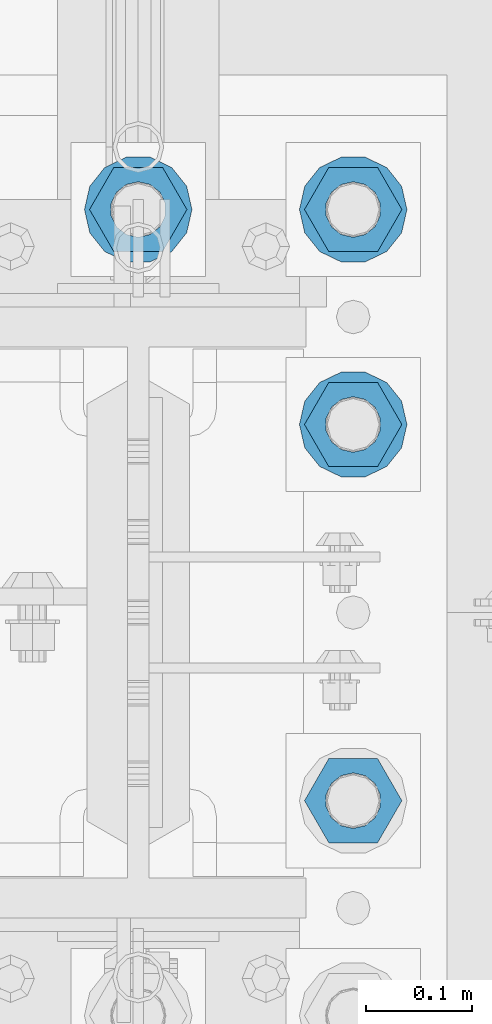
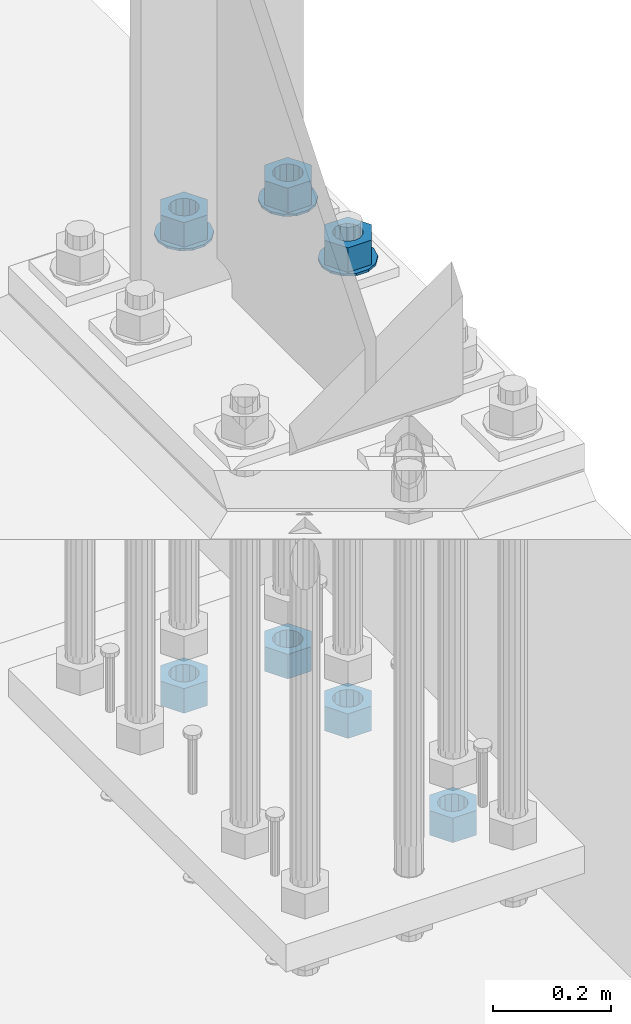
# One storey, part 858 of 1876: 10 columns, 1 element without a shape of its own.
"""IFC2X3 building model written with IfcOpenShell, lengths in millimetres."""

from ifc_helpers import new_model, si_unit, frame, origin_with_axes, place, context, subcontext, project, spatial, faceted_brep, material, type_object, element, aggregate, save


model = new_model("IFC2X3")

# Units and contexts
model_context = context("Model", 3, precision=1e-05, world=origin_with_axes())
body_context = subcontext(model_context, "Body", "Model", "MODEL_VIEW")
ifc_project = project(units=[si_unit("LENGTHUNIT", "METRE", prefix="MILLI"), si_unit("AREAUNIT", "SQUARE_METRE"), si_unit("VOLUMEUNIT", "CUBIC_METRE"), si_unit("MASSUNIT", "GRAM", prefix="KILO"), si_unit("TIMEUNIT", "SECOND"), si_unit("PLANEANGLEUNIT", "RADIAN"), si_unit("SOLIDANGLEUNIT", "STERADIAN"), si_unit("THERMODYNAMICTEMPERATUREUNIT", "DEGREE_CELSIUS"), si_unit("LUMINOUSINTENSITYUNIT", "LUMEN")], contexts=[model_context])

# Site, building, storey
site_placement = place(None, origin_with_axes())
site = spatial("IfcSite", under=ifc_project, at=site_placement, CompositionType="ELEMENT")
building_placement = place(site_placement, origin_with_axes())
building = spatial("IfcBuilding", under=site, at=building_placement, Name="Undefined", CompositionType="ELEMENT")
storey_placement = place(building_placement, origin_with_axes())
storey = spatial("IfcBuildingStorey", under=building, at=storey_placement, Name="Undefined", CompositionType="ELEMENT", Elevation=0.0)

# Assembly, columns
assembly_placement = place(storey_placement, origin_with_axes())
assembly = element("IfcElementAssembly", 1, at=assembly_placement, inside=storey, Name="TEMPLATE", AssemblyPlace="NOTDEFINED", PredefinedType="RIGID_FRAME")
ifc_material_1 = material(Name="STEEL/F436")
column_type_1 = type_object("IfcColumnType", Name="2_WASHER", PredefinedType="NOTDEFINED")
column_1_placement = place(assembly_placement, frame((7823.2, 7797.8, 119.0625), z_axis=(0.0, 1.0, 0.0), x_axis=(0.0, 0.0, -1.0)))
column_1 = element("IfcColumn", 2, at=column_1_placement, type_object=column_type_1, material=ifc_material_1, Name="WASHER", ObjectType="2_WASHER", context=body_context, shape_type="Brep", body=[
    faceted_brep([(0.0, -50.7999992370605, 9.09494701772928e-13), (0.0, -45.7692178020588, -22.0412936161442), (4.7625, -45.7692178020588, -22.0412936161442), (4.7625, -50.7999992370605, 9.09494701772928e-13), (0.0, -31.6732814587394, -39.7170387128856), (4.7625, -31.6732814587394, -39.7170387128856), (0.0, -11.3040632752118, -49.5263371950259), (4.7625, -11.3040632752118, -49.5263371950259), (0.0, 11.30406327521, -49.5263371950264), (4.7625, 11.30406327521, -49.5263371950264), (0.0, 31.6732814587385, -39.7170387128867), (4.7625, 31.6732814587385, -39.7170387128867), (0.0, 45.7692178020579, -22.041293616146), (4.7625, 45.7692178020579, -22.041293616146), (0.0, 50.7999992370605, -9.09494701772928e-13), (4.7625, 50.7999992370605, -9.09494701772928e-13), (0.0, 45.7692178020588, 22.0412936161442), (4.7625, 45.7692178020588, 22.0412936161442), (0.0, 31.6732814587394, 39.7170387128856), (4.7625, 31.6732814587394, 39.7170387128856), (0.0, 11.3040632752118, 49.5263371950259), (4.7625, 11.3040632752118, 49.5263371950259), (0.0, -11.30406327521, 49.5263371950264), (4.7625, -11.30406327521, 49.5263371950264), (0.0, -31.6732814587385, 39.7170387128867), (4.7625, -31.6732814587385, 39.7170387128867), (0.0, -45.7692178020579, 22.041293616146), (4.7625, -45.7692178020579, 22.041293616146), (0.0, 0.0, 26.9869995117188), (0.0, 11.7093983825444, 24.3146012721213), (4.7625, 11.7093983825444, 24.3146012721213), (4.7625, 0.0, 26.9869995117188), (0.0, 21.0996520289491, 16.8262864224157), (4.7625, 21.0996520289491, 16.8262864224157), (0.0, 26.3108629296712, 6.00524193584533), (4.7625, 26.3108629296712, 6.00524193584533), (0.0, 26.3108629296712, -6.00524193584533), (4.7625, 26.3108629296712, -6.00524193584533), (0.0, 21.0996520289491, -16.8262864224157), (4.7625, 21.0996520289491, -16.8262864224157), (0.0, 11.7093983825444, -24.3146012721213), (4.7625, 11.7093983825444, -24.3146012721213), (0.0, 0.0, -26.9869995117188), (4.7625, 0.0, -26.9869995117188), (0.0, -11.7093983825444, -24.3146012721213), (4.7625, -11.7093983825444, -24.3146012721213), (0.0, -21.0996520289491, -16.8262864224157), (4.7625, -21.0996520289491, -16.8262864224157), (0.0, -26.3108629296712, -6.00524193584533), (4.7625, -26.3108629296712, -6.00524193584533), (0.0, -26.3108629296712, 6.00524193584533), (4.7625, -26.3108629296712, 6.00524193584533), (0.0, -21.0996520289491, 16.8262864224157), (4.7625, -21.0996520289491, 16.8262864224157), (0.0, -11.7093983825444, 24.3146012721213), (4.7625, -11.7093983825444, 24.3146012721213)], [[[0, 1, 2, 3]], [[1, 4, 5, 2]], [[4, 6, 7, 5]], [[6, 8, 9, 7]], [[8, 10, 11, 9]], [[10, 12, 13, 11]], [[12, 14, 15, 13]], [[14, 16, 17, 15]], [[16, 18, 19, 17]], [[18, 20, 21, 19]], [[20, 22, 23, 21]], [[22, 24, 25, 23]], [[24, 26, 27, 25]], [[26, 0, 3, 27]], [[28, 29, 30, 31]], [[29, 32, 33, 30]], [[32, 34, 35, 33]], [[34, 36, 37, 35]], [[36, 38, 39, 37]], [[38, 40, 41, 39]], [[40, 42, 43, 41]], [[42, 44, 45, 43]], [[44, 46, 47, 45]], [[46, 48, 49, 47]], [[48, 50, 51, 49]], [[50, 52, 53, 51]], [[52, 54, 55, 53]], [[54, 28, 31, 55]], [[5, 7, 9, 11, 13, 15, 17, 19, 21, 23, 25, 27, 3, 2], [33, 35, 37, 39, 41, 43, 45, 47, 49, 51, 53, 55, 31, 30]], [[26, 24, 22, 20, 18, 16, 14, 12, 10, 8, 6, 4, 1, 0], [54, 52, 50, 48, 46, 44, 42, 40, 38, 36, 34, 32, 29, 28]]]),
])
column_2_placement = place(assembly_placement, frame((7620.0, 8001.0, 119.0625), z_axis=(0.0, -1.0, 0.0), x_axis=(0.0, 0.0, -1.0)))
column_2 = element("IfcColumn", 3, at=column_2_placement, type_object=column_type_1, material=ifc_material_1, Name="WASHER", ObjectType="2_WASHER", context=body_context, shape_type="Brep", body=[
    faceted_brep([(0.0, -50.7999992370605, 9.09494701772928e-13), (0.0, -45.7692178020588, -22.0412936161442), (4.7625, -45.7692178020588, -22.0412936161442), (4.7625, -50.7999992370605, 9.09494701772928e-13), (0.0, -31.6732814587394, -39.7170387128856), (4.7625, -31.6732814587394, -39.7170387128856), (0.0, -11.3040632752118, -49.5263371950259), (4.7625, -11.3040632752118, -49.5263371950259), (0.0, 11.30406327521, -49.5263371950264), (4.7625, 11.30406327521, -49.5263371950264), (0.0, 31.6732814587385, -39.7170387128867), (4.7625, 31.6732814587385, -39.7170387128867), (0.0, 45.7692178020579, -22.041293616146), (4.7625, 45.7692178020579, -22.041293616146), (0.0, 50.7999992370605, -9.09494701772928e-13), (4.7625, 50.7999992370605, -9.09494701772928e-13), (0.0, 45.7692178020588, 22.0412936161442), (4.7625, 45.7692178020588, 22.0412936161442), (0.0, 31.6732814587394, 39.7170387128856), (4.7625, 31.6732814587394, 39.7170387128856), (0.0, 11.3040632752118, 49.5263371950259), (4.7625, 11.3040632752118, 49.5263371950259), (0.0, -11.30406327521, 49.5263371950264), (4.7625, -11.30406327521, 49.5263371950264), (0.0, -31.6732814587385, 39.7170387128867), (4.7625, -31.6732814587385, 39.7170387128867), (0.0, -45.7692178020579, 22.041293616146), (4.7625, -45.7692178020579, 22.041293616146), (0.0, 0.0, 26.9869995117188), (0.0, 11.7093983825444, 24.3146012721213), (4.7625, 11.7093983825444, 24.3146012721213), (4.7625, 0.0, 26.9869995117188), (0.0, 21.0996520289491, 16.8262864224157), (4.7625, 21.0996520289491, 16.8262864224157), (0.0, 26.3108629296712, 6.00524193584533), (4.7625, 26.3108629296712, 6.00524193584533), (0.0, 26.3108629296712, -6.00524193584533), (4.7625, 26.3108629296712, -6.00524193584533), (0.0, 21.0996520289491, -16.8262864224157), (4.7625, 21.0996520289491, -16.8262864224157), (0.0, 11.7093983825444, -24.3146012721213), (4.7625, 11.7093983825444, -24.3146012721213), (0.0, 0.0, -26.9869995117188), (4.7625, 0.0, -26.9869995117188), (0.0, -11.7093983825444, -24.3146012721213), (4.7625, -11.7093983825444, -24.3146012721213), (0.0, -21.0996520289491, -16.8262864224157), (4.7625, -21.0996520289491, -16.8262864224157), (0.0, -26.3108629296712, -6.00524193584533), (4.7625, -26.3108629296712, -6.00524193584533), (0.0, -26.3108629296712, 6.00524193584533), (4.7625, -26.3108629296712, 6.00524193584533), (0.0, -21.0996520289491, 16.8262864224157), (4.7625, -21.0996520289491, 16.8262864224157), (0.0, -11.7093983825444, 24.3146012721213), (4.7625, -11.7093983825444, 24.3146012721213)], [[[0, 1, 2, 3]], [[1, 4, 5, 2]], [[4, 6, 7, 5]], [[6, 8, 9, 7]], [[8, 10, 11, 9]], [[10, 12, 13, 11]], [[12, 14, 15, 13]], [[14, 16, 17, 15]], [[16, 18, 19, 17]], [[18, 20, 21, 19]], [[20, 22, 23, 21]], [[22, 24, 25, 23]], [[24, 26, 27, 25]], [[26, 0, 3, 27]], [[28, 29, 30, 31]], [[29, 32, 33, 30]], [[32, 34, 35, 33]], [[34, 36, 37, 35]], [[36, 38, 39, 37]], [[38, 40, 41, 39]], [[40, 42, 43, 41]], [[42, 44, 45, 43]], [[44, 46, 47, 45]], [[46, 48, 49, 47]], [[48, 50, 51, 49]], [[50, 52, 53, 51]], [[52, 54, 55, 53]], [[54, 28, 31, 55]], [[5, 7, 9, 11, 13, 15, 17, 19, 21, 23, 25, 27, 3, 2], [33, 35, 37, 39, 41, 43, 45, 47, 49, 51, 53, 55, 31, 30]], [[26, 24, 22, 20, 18, 16, 14, 12, 10, 8, 6, 4, 1, 0], [54, 52, 50, 48, 46, 44, 42, 40, 38, 36, 34, 32, 29, 28]]]),
])
column_3_placement = place(assembly_placement, frame((7823.2, 8001.0, 119.0625), z_axis=(0.0, 1.0, 0.0), x_axis=(0.0, 0.0, -1.0)))
column_3 = element("IfcColumn", 4, at=column_3_placement, type_object=column_type_1, material=ifc_material_1, Name="WASHER", ObjectType="2_WASHER", context=body_context, shape_type="Brep", body=[
    faceted_brep([(0.0, -50.7999992370605, 9.09494701772928e-13), (0.0, -45.7692178020588, -22.0412936161442), (4.7625, -45.7692178020588, -22.0412936161442), (4.7625, -50.7999992370605, 9.09494701772928e-13), (0.0, -31.6732814587394, -39.7170387128856), (4.7625, -31.6732814587394, -39.7170387128856), (0.0, -11.3040632752118, -49.5263371950259), (4.7625, -11.3040632752118, -49.5263371950259), (0.0, 11.30406327521, -49.5263371950264), (4.7625, 11.30406327521, -49.5263371950264), (0.0, 31.6732814587385, -39.7170387128867), (4.7625, 31.6732814587385, -39.7170387128867), (0.0, 45.7692178020579, -22.041293616146), (4.7625, 45.7692178020579, -22.041293616146), (0.0, 50.7999992370605, -9.09494701772928e-13), (4.7625, 50.7999992370605, -9.09494701772928e-13), (0.0, 45.7692178020588, 22.0412936161442), (4.7625, 45.7692178020588, 22.0412936161442), (0.0, 31.6732814587394, 39.7170387128856), (4.7625, 31.6732814587394, 39.7170387128856), (0.0, 11.3040632752118, 49.5263371950259), (4.7625, 11.3040632752118, 49.5263371950259), (0.0, -11.30406327521, 49.5263371950264), (4.7625, -11.30406327521, 49.5263371950264), (0.0, -31.6732814587385, 39.7170387128867), (4.7625, -31.6732814587385, 39.7170387128867), (0.0, -45.7692178020579, 22.041293616146), (4.7625, -45.7692178020579, 22.041293616146), (0.0, 0.0, 26.9869995117188), (0.0, 11.7093983825444, 24.3146012721213), (4.7625, 11.7093983825444, 24.3146012721213), (4.7625, 0.0, 26.9869995117188), (0.0, 21.0996520289491, 16.8262864224157), (4.7625, 21.0996520289491, 16.8262864224157), (0.0, 26.3108629296712, 6.00524193584533), (4.7625, 26.3108629296712, 6.00524193584533), (0.0, 26.3108629296712, -6.00524193584533), (4.7625, 26.3108629296712, -6.00524193584533), (0.0, 21.0996520289491, -16.8262864224157), (4.7625, 21.0996520289491, -16.8262864224157), (0.0, 11.7093983825444, -24.3146012721213), (4.7625, 11.7093983825444, -24.3146012721213), (0.0, 0.0, -26.9869995117188), (4.7625, 0.0, -26.9869995117188), (0.0, -11.7093983825444, -24.3146012721213), (4.7625, -11.7093983825444, -24.3146012721213), (0.0, -21.0996520289491, -16.8262864224157), (4.7625, -21.0996520289491, -16.8262864224157), (0.0, -26.3108629296712, -6.00524193584533), (4.7625, -26.3108629296712, -6.00524193584533), (0.0, -26.3108629296712, 6.00524193584533), (4.7625, -26.3108629296712, 6.00524193584533), (0.0, -21.0996520289491, 16.8262864224157), (4.7625, -21.0996520289491, 16.8262864224157), (0.0, -11.7093983825444, 24.3146012721213), (4.7625, -11.7093983825444, 24.3146012721213)], [[[0, 1, 2, 3]], [[1, 4, 5, 2]], [[4, 6, 7, 5]], [[6, 8, 9, 7]], [[8, 10, 11, 9]], [[10, 12, 13, 11]], [[12, 14, 15, 13]], [[14, 16, 17, 15]], [[16, 18, 19, 17]], [[18, 20, 21, 19]], [[20, 22, 23, 21]], [[22, 24, 25, 23]], [[24, 26, 27, 25]], [[26, 0, 3, 27]], [[28, 29, 30, 31]], [[29, 32, 33, 30]], [[32, 34, 35, 33]], [[34, 36, 37, 35]], [[36, 38, 39, 37]], [[38, 40, 41, 39]], [[40, 42, 43, 41]], [[42, 44, 45, 43]], [[44, 46, 47, 45]], [[46, 48, 49, 47]], [[48, 50, 51, 49]], [[50, 52, 53, 51]], [[52, 54, 55, 53]], [[54, 28, 31, 55]], [[5, 7, 9, 11, 13, 15, 17, 19, 21, 23, 25, 27, 3, 2], [33, 35, 37, 39, 41, 43, 45, 47, 49, 51, 53, 55, 31, 30]], [[26, 24, 22, 20, 18, 16, 14, 12, 10, 8, 6, 4, 1, 0], [54, 52, 50, 48, 46, 44, 42, 40, 38, 36, 34, 32, 29, 28]]]),
])
ifc_material_2 = material(Name="STEEL/A563")
column_type_2 = type_object("IfcColumnType", Name="2_HEAVY_HEX_NUT", PredefinedType="NOTDEFINED")
column_4_placement = place(assembly_placement, frame((7823.2, 7442.2, -793.75), z_axis=(0.0, 1.0, 0.0), x_axis=(0.0, 0.0, -1.0)))
column_4 = element("IfcColumn", 5, at=column_4_placement, type_object=column_type_2, material=ifc_material_2, Name="NUT", ObjectType="2_HEAVY_HEX_NUT", context=body_context, shape_type="Brep", body=[
    faceted_brep([(0.0, -46.0369987487793, 9.09494701772928e-13), (0.0, -23.0184993743896, -39.869213104248), (50.8, -23.0184993743896, -39.869213104248), (50.8, -46.0369987487793, 9.09494701772928e-13), (0.0, 23.0184993743896, -39.869213104248), (50.8, 23.0184993743896, -39.869213104248), (0.0, 46.0369987487793, -9.09494701772928e-13), (50.8, 46.0369987487793, -9.09494701772928e-13), (0.0, 23.0184993743896, 39.869213104248), (50.8, 23.0184993743896, 39.869213104248), (0.0, -23.0184993743896, 39.869213104248), (50.8, -23.0184993743896, 39.869213104248), (0.0, 0.0, 26.1940002441406), (0.0, 11.3650617044514, 23.5999013092769), (50.8, 11.3650617044513, 23.5999013092771), (50.8, 0.0, 26.1940002441406), (0.0, 20.4791109456437, 16.3316083006703), (50.8, 20.4791109456439, 16.3316083006703), (0.0, 25.5370200498346, 5.82867859874477), (50.8, 25.5370200498343, 5.82867859874455), (0.0, 25.5370200498346, -5.82867859874477), (50.8, 25.5370200498343, -5.82867859874455), (0.0, 20.4791109456437, -16.3316083006703), (50.8, 20.4791109456439, -16.3316083006703), (0.0, 11.3650617044514, -23.5999013092769), (50.8, 11.3650617044514, -23.5999013092771), (0.0, 0.0, -26.1940002441406), (50.8, 0.0, -26.1940002441406), (0.0, -11.3650617044514, -23.5999013092769), (50.8, -11.3650617044513, -23.5999013092771), (0.0, -20.4791109456437, -16.3316083006703), (50.8, -20.4791109456439, -16.3316083006703), (0.0, -25.5370200498346, -5.82867859874477), (50.8, -25.5370200498343, -5.82867859874455), (0.0, -25.5370200498346, 5.82867859874477), (50.8, -25.5370200498343, 5.82867859874455), (0.0, -20.4791109456437, 16.3316083006703), (50.8, -20.4791109456439, 16.3316083006703), (0.0, -11.3650617044514, 23.5999013092769), (50.8, -11.3650617044514, 23.5999013092771)], [[[0, 1, 2, 3]], [[1, 4, 5, 2]], [[4, 6, 7, 5]], [[6, 8, 9, 7]], [[8, 10, 11, 9]], [[10, 0, 3, 11]], [[12, 13, 14, 15]], [[13, 16, 17, 14]], [[16, 18, 19, 17]], [[18, 20, 21, 19]], [[20, 22, 23, 21]], [[22, 24, 25, 23]], [[24, 26, 27, 25]], [[26, 28, 29, 27]], [[28, 30, 31, 29]], [[30, 32, 33, 31]], [[32, 34, 35, 33]], [[34, 36, 37, 35]], [[36, 38, 39, 37]], [[38, 12, 15, 39]], [[5, 7, 9, 11, 3, 2], [17, 19, 21, 23, 25, 27, 29, 31, 33, 35, 37, 39, 15, 14]], [[10, 8, 6, 4, 1, 0], [38, 36, 34, 32, 30, 28, 26, 24, 22, 20, 18, 16, 13, 12]]]),
])
column_5_placement = place(assembly_placement, frame((7823.2, 7797.8, 169.8625), z_axis=(0.0, 1.0, 0.0), x_axis=(0.0, 0.0, -1.0)))
column_5 = element("IfcColumn", 6, at=column_5_placement, type_object=column_type_2, material=ifc_material_2, Name="NUT", ObjectType="2_HEAVY_HEX_NUT", context=body_context, shape_type="Brep", body=[
    faceted_brep([(0.0, -46.0369987487793, 9.09494701772928e-13), (0.0, -23.0184993743896, -39.869213104248), (50.8, -23.0184993743896, -39.869213104248), (50.8, -46.0369987487793, 9.09494701772928e-13), (0.0, 23.0184993743896, -39.869213104248), (50.8, 23.0184993743896, -39.869213104248), (0.0, 46.0369987487793, -9.09494701772928e-13), (50.8, 46.0369987487793, -9.09494701772928e-13), (0.0, 23.0184993743896, 39.869213104248), (50.8, 23.0184993743896, 39.869213104248), (0.0, -23.0184993743896, 39.869213104248), (50.8, -23.0184993743896, 39.869213104248), (0.0, 0.0, 26.1940002441406), (0.0, 11.3650617044514, 23.5999013092769), (50.8, 11.3650617044513, 23.5999013092771), (50.8, 0.0, 26.1940002441406), (0.0, 20.4791109456437, 16.3316083006703), (50.8, 20.4791109456439, 16.3316083006703), (0.0, 25.5370200498346, 5.82867859874477), (50.8, 25.5370200498343, 5.82867859874455), (0.0, 25.5370200498346, -5.82867859874477), (50.8, 25.5370200498343, -5.82867859874455), (0.0, 20.4791109456437, -16.3316083006703), (50.8, 20.4791109456439, -16.3316083006703), (0.0, 11.3650617044514, -23.5999013092769), (50.8, 11.3650617044514, -23.5999013092771), (0.0, 0.0, -26.1940002441406), (50.8, 0.0, -26.1940002441406), (0.0, -11.3650617044514, -23.5999013092769), (50.8, -11.3650617044513, -23.5999013092771), (0.0, -20.4791109456437, -16.3316083006703), (50.8, -20.4791109456439, -16.3316083006703), (0.0, -25.5370200498346, -5.82867859874477), (50.8, -25.5370200498343, -5.82867859874455), (0.0, -25.5370200498346, 5.82867859874477), (50.8, -25.5370200498343, 5.82867859874455), (0.0, -20.4791109456437, 16.3316083006703), (50.8, -20.4791109456439, 16.3316083006703), (0.0, -11.3650617044514, 23.5999013092769), (50.8, -11.3650617044514, 23.5999013092771)], [[[0, 1, 2, 3]], [[1, 4, 5, 2]], [[4, 6, 7, 5]], [[6, 8, 9, 7]], [[8, 10, 11, 9]], [[10, 0, 3, 11]], [[12, 13, 14, 15]], [[13, 16, 17, 14]], [[16, 18, 19, 17]], [[18, 20, 21, 19]], [[20, 22, 23, 21]], [[22, 24, 25, 23]], [[24, 26, 27, 25]], [[26, 28, 29, 27]], [[28, 30, 31, 29]], [[30, 32, 33, 31]], [[32, 34, 35, 33]], [[34, 36, 37, 35]], [[36, 38, 39, 37]], [[38, 12, 15, 39]], [[5, 7, 9, 11, 3, 2], [17, 19, 21, 23, 25, 27, 29, 31, 33, 35, 37, 39, 15, 14]], [[10, 8, 6, 4, 1, 0], [38, 36, 34, 32, 30, 28, 26, 24, 22, 20, 18, 16, 13, 12]]]),
])
column_6_placement = place(assembly_placement, frame((7823.2, 7797.8, -793.75), z_axis=(0.0, 1.0, 0.0), x_axis=(0.0, 0.0, -1.0)))
column_6 = element("IfcColumn", 7, at=column_6_placement, type_object=column_type_2, material=ifc_material_2, Name="NUT", ObjectType="2_HEAVY_HEX_NUT", context=body_context, shape_type="Brep", body=[
    faceted_brep([(0.0, -46.0369987487793, 9.09494701772928e-13), (0.0, -23.0184993743896, -39.869213104248), (50.8, -23.0184993743896, -39.869213104248), (50.8, -46.0369987487793, 9.09494701772928e-13), (0.0, 23.0184993743896, -39.869213104248), (50.8, 23.0184993743896, -39.869213104248), (0.0, 46.0369987487793, -9.09494701772928e-13), (50.8, 46.0369987487793, -9.09494701772928e-13), (0.0, 23.0184993743896, 39.869213104248), (50.8, 23.0184993743896, 39.869213104248), (0.0, -23.0184993743896, 39.869213104248), (50.8, -23.0184993743896, 39.869213104248), (0.0, 0.0, 26.1940002441406), (0.0, 11.3650617044514, 23.5999013092769), (50.8, 11.3650617044513, 23.5999013092771), (50.8, 0.0, 26.1940002441406), (0.0, 20.4791109456437, 16.3316083006703), (50.8, 20.4791109456439, 16.3316083006703), (0.0, 25.5370200498346, 5.82867859874477), (50.8, 25.5370200498343, 5.82867859874455), (0.0, 25.5370200498346, -5.82867859874477), (50.8, 25.5370200498343, -5.82867859874455), (0.0, 20.4791109456437, -16.3316083006703), (50.8, 20.4791109456439, -16.3316083006703), (0.0, 11.3650617044514, -23.5999013092769), (50.8, 11.3650617044514, -23.5999013092771), (0.0, 0.0, -26.1940002441406), (50.8, 0.0, -26.1940002441406), (0.0, -11.3650617044514, -23.5999013092769), (50.8, -11.3650617044513, -23.5999013092771), (0.0, -20.4791109456437, -16.3316083006703), (50.8, -20.4791109456439, -16.3316083006703), (0.0, -25.5370200498346, -5.82867859874477), (50.8, -25.5370200498343, -5.82867859874455), (0.0, -25.5370200498346, 5.82867859874477), (50.8, -25.5370200498343, 5.82867859874455), (0.0, -20.4791109456437, 16.3316083006703), (50.8, -20.4791109456439, 16.3316083006703), (0.0, -11.3650617044514, 23.5999013092769), (50.8, -11.3650617044514, 23.5999013092771)], [[[0, 1, 2, 3]], [[1, 4, 5, 2]], [[4, 6, 7, 5]], [[6, 8, 9, 7]], [[8, 10, 11, 9]], [[10, 0, 3, 11]], [[12, 13, 14, 15]], [[13, 16, 17, 14]], [[16, 18, 19, 17]], [[18, 20, 21, 19]], [[20, 22, 23, 21]], [[22, 24, 25, 23]], [[24, 26, 27, 25]], [[26, 28, 29, 27]], [[28, 30, 31, 29]], [[30, 32, 33, 31]], [[32, 34, 35, 33]], [[34, 36, 37, 35]], [[36, 38, 39, 37]], [[38, 12, 15, 39]], [[5, 7, 9, 11, 3, 2], [17, 19, 21, 23, 25, 27, 29, 31, 33, 35, 37, 39, 15, 14]], [[10, 8, 6, 4, 1, 0], [38, 36, 34, 32, 30, 28, 26, 24, 22, 20, 18, 16, 13, 12]]]),
])
column_7_placement = place(assembly_placement, frame((7620.0, 8001.0, 169.8625), z_axis=(0.0, -1.0, 0.0), x_axis=(0.0, 0.0, -1.0)))
column_7 = element("IfcColumn", 8, at=column_7_placement, type_object=column_type_2, material=ifc_material_2, Name="NUT", ObjectType="2_HEAVY_HEX_NUT", context=body_context, shape_type="Brep", body=[
    faceted_brep([(0.0, -46.0369987487793, 9.09494701772928e-13), (0.0, -23.0184993743896, -39.869213104248), (50.8, -23.0184993743896, -39.869213104248), (50.8, -46.0369987487793, 9.09494701772928e-13), (0.0, 23.0184993743896, -39.869213104248), (50.8, 23.0184993743896, -39.869213104248), (0.0, 46.0369987487793, -9.09494701772928e-13), (50.8, 46.0369987487793, -9.09494701772928e-13), (0.0, 23.0184993743896, 39.869213104248), (50.8, 23.0184993743896, 39.869213104248), (0.0, -23.0184993743896, 39.869213104248), (50.8, -23.0184993743896, 39.869213104248), (0.0, 0.0, 26.1940002441406), (0.0, 11.3650617044514, 23.5999013092769), (50.8, 11.3650617044513, 23.5999013092771), (50.8, 0.0, 26.1940002441406), (0.0, 20.4791109456437, 16.3316083006703), (50.8, 20.4791109456439, 16.3316083006703), (0.0, 25.5370200498346, 5.82867859874477), (50.8, 25.5370200498343, 5.82867859874455), (0.0, 25.5370200498346, -5.82867859874477), (50.8, 25.5370200498343, -5.82867859874455), (0.0, 20.4791109456437, -16.3316083006703), (50.8, 20.4791109456439, -16.3316083006703), (0.0, 11.3650617044514, -23.5999013092769), (50.8, 11.3650617044514, -23.5999013092771), (0.0, 0.0, -26.1940002441406), (50.8, 0.0, -26.1940002441406), (0.0, -11.3650617044514, -23.5999013092769), (50.8, -11.3650617044513, -23.5999013092771), (0.0, -20.4791109456437, -16.3316083006703), (50.8, -20.4791109456439, -16.3316083006703), (0.0, -25.5370200498346, -5.82867859874477), (50.8, -25.5370200498343, -5.82867859874455), (0.0, -25.5370200498346, 5.82867859874477), (50.8, -25.5370200498343, 5.82867859874455), (0.0, -20.4791109456437, 16.3316083006703), (50.8, -20.4791109456439, 16.3316083006703), (0.0, -11.3650617044514, 23.5999013092769), (50.8, -11.3650617044514, 23.5999013092771)], [[[0, 1, 2, 3]], [[1, 4, 5, 2]], [[4, 6, 7, 5]], [[6, 8, 9, 7]], [[8, 10, 11, 9]], [[10, 0, 3, 11]], [[12, 13, 14, 15]], [[13, 16, 17, 14]], [[16, 18, 19, 17]], [[18, 20, 21, 19]], [[20, 22, 23, 21]], [[22, 24, 25, 23]], [[24, 26, 27, 25]], [[26, 28, 29, 27]], [[28, 30, 31, 29]], [[30, 32, 33, 31]], [[32, 34, 35, 33]], [[34, 36, 37, 35]], [[36, 38, 39, 37]], [[38, 12, 15, 39]], [[5, 7, 9, 11, 3, 2], [17, 19, 21, 23, 25, 27, 29, 31, 33, 35, 37, 39, 15, 14]], [[10, 8, 6, 4, 1, 0], [38, 36, 34, 32, 30, 28, 26, 24, 22, 20, 18, 16, 13, 12]]]),
])
column_8_placement = place(assembly_placement, frame((7620.0, 8001.0, -793.75), z_axis=(0.0, -1.0, 0.0), x_axis=(0.0, 0.0, -1.0)))
column_8 = element("IfcColumn", 9, at=column_8_placement, type_object=column_type_2, material=ifc_material_2, Name="NUT", ObjectType="2_HEAVY_HEX_NUT", context=body_context, shape_type="Brep", body=[
    faceted_brep([(0.0, -46.0369987487793, 9.09494701772928e-13), (0.0, -23.0184993743896, -39.869213104248), (50.8, -23.0184993743896, -39.869213104248), (50.8, -46.0369987487793, 9.09494701772928e-13), (0.0, 23.0184993743896, -39.869213104248), (50.8, 23.0184993743896, -39.869213104248), (0.0, 46.0369987487793, -9.09494701772928e-13), (50.8, 46.0369987487793, -9.09494701772928e-13), (0.0, 23.0184993743896, 39.869213104248), (50.8, 23.0184993743896, 39.869213104248), (0.0, -23.0184993743896, 39.869213104248), (50.8, -23.0184993743896, 39.869213104248), (0.0, 0.0, 26.1940002441406), (0.0, 11.3650617044514, 23.5999013092769), (50.8, 11.3650617044513, 23.5999013092771), (50.8, 0.0, 26.1940002441406), (0.0, 20.4791109456437, 16.3316083006703), (50.8, 20.4791109456439, 16.3316083006703), (0.0, 25.5370200498346, 5.82867859874477), (50.8, 25.5370200498343, 5.82867859874455), (0.0, 25.5370200498346, -5.82867859874477), (50.8, 25.5370200498343, -5.82867859874455), (0.0, 20.4791109456437, -16.3316083006703), (50.8, 20.4791109456439, -16.3316083006703), (0.0, 11.3650617044514, -23.5999013092769), (50.8, 11.3650617044514, -23.5999013092771), (0.0, 0.0, -26.1940002441406), (50.8, 0.0, -26.1940002441406), (0.0, -11.3650617044514, -23.5999013092769), (50.8, -11.3650617044513, -23.5999013092771), (0.0, -20.4791109456437, -16.3316083006703), (50.8, -20.4791109456439, -16.3316083006703), (0.0, -25.5370200498346, -5.82867859874477), (50.8, -25.5370200498343, -5.82867859874455), (0.0, -25.5370200498346, 5.82867859874477), (50.8, -25.5370200498343, 5.82867859874455), (0.0, -20.4791109456437, 16.3316083006703), (50.8, -20.4791109456439, 16.3316083006703), (0.0, -11.3650617044514, 23.5999013092769), (50.8, -11.3650617044514, 23.5999013092771)], [[[0, 1, 2, 3]], [[1, 4, 5, 2]], [[4, 6, 7, 5]], [[6, 8, 9, 7]], [[8, 10, 11, 9]], [[10, 0, 3, 11]], [[12, 13, 14, 15]], [[13, 16, 17, 14]], [[16, 18, 19, 17]], [[18, 20, 21, 19]], [[20, 22, 23, 21]], [[22, 24, 25, 23]], [[24, 26, 27, 25]], [[26, 28, 29, 27]], [[28, 30, 31, 29]], [[30, 32, 33, 31]], [[32, 34, 35, 33]], [[34, 36, 37, 35]], [[36, 38, 39, 37]], [[38, 12, 15, 39]], [[5, 7, 9, 11, 3, 2], [17, 19, 21, 23, 25, 27, 29, 31, 33, 35, 37, 39, 15, 14]], [[10, 8, 6, 4, 1, 0], [38, 36, 34, 32, 30, 28, 26, 24, 22, 20, 18, 16, 13, 12]]]),
])
column_9_placement = place(assembly_placement, frame((7823.2, 8001.0, 169.8625), z_axis=(0.0, 1.0, 0.0), x_axis=(0.0, 0.0, -1.0)))
column_9 = element("IfcColumn", 10, at=column_9_placement, type_object=column_type_2, material=ifc_material_2, Name="NUT", ObjectType="2_HEAVY_HEX_NUT", context=body_context, shape_type="Brep", body=[
    faceted_brep([(0.0, -46.0369987487793, 9.09494701772928e-13), (0.0, -23.0184993743896, -39.869213104248), (50.8, -23.0184993743896, -39.869213104248), (50.8, -46.0369987487793, 9.09494701772928e-13), (0.0, 23.0184993743896, -39.869213104248), (50.8, 23.0184993743896, -39.869213104248), (0.0, 46.0369987487793, -9.09494701772928e-13), (50.8, 46.0369987487793, -9.09494701772928e-13), (0.0, 23.0184993743896, 39.869213104248), (50.8, 23.0184993743896, 39.869213104248), (0.0, -23.0184993743896, 39.869213104248), (50.8, -23.0184993743896, 39.869213104248), (0.0, 0.0, 26.1940002441406), (0.0, 11.3650617044514, 23.5999013092769), (50.8, 11.3650617044513, 23.5999013092771), (50.8, 0.0, 26.1940002441406), (0.0, 20.4791109456437, 16.3316083006703), (50.8, 20.4791109456439, 16.3316083006703), (0.0, 25.5370200498346, 5.82867859874477), (50.8, 25.5370200498343, 5.82867859874455), (0.0, 25.5370200498346, -5.82867859874477), (50.8, 25.5370200498343, -5.82867859874455), (0.0, 20.4791109456437, -16.3316083006703), (50.8, 20.4791109456439, -16.3316083006703), (0.0, 11.3650617044514, -23.5999013092769), (50.8, 11.3650617044514, -23.5999013092771), (0.0, 0.0, -26.1940002441406), (50.8, 0.0, -26.1940002441406), (0.0, -11.3650617044514, -23.5999013092769), (50.8, -11.3650617044513, -23.5999013092771), (0.0, -20.4791109456437, -16.3316083006703), (50.8, -20.4791109456439, -16.3316083006703), (0.0, -25.5370200498346, -5.82867859874477), (50.8, -25.5370200498343, -5.82867859874455), (0.0, -25.5370200498346, 5.82867859874477), (50.8, -25.5370200498343, 5.82867859874455), (0.0, -20.4791109456437, 16.3316083006703), (50.8, -20.4791109456439, 16.3316083006703), (0.0, -11.3650617044514, 23.5999013092769), (50.8, -11.3650617044514, 23.5999013092771)], [[[0, 1, 2, 3]], [[1, 4, 5, 2]], [[4, 6, 7, 5]], [[6, 8, 9, 7]], [[8, 10, 11, 9]], [[10, 0, 3, 11]], [[12, 13, 14, 15]], [[13, 16, 17, 14]], [[16, 18, 19, 17]], [[18, 20, 21, 19]], [[20, 22, 23, 21]], [[22, 24, 25, 23]], [[24, 26, 27, 25]], [[26, 28, 29, 27]], [[28, 30, 31, 29]], [[30, 32, 33, 31]], [[32, 34, 35, 33]], [[34, 36, 37, 35]], [[36, 38, 39, 37]], [[38, 12, 15, 39]], [[5, 7, 9, 11, 3, 2], [17, 19, 21, 23, 25, 27, 29, 31, 33, 35, 37, 39, 15, 14]], [[10, 8, 6, 4, 1, 0], [38, 36, 34, 32, 30, 28, 26, 24, 22, 20, 18, 16, 13, 12]]]),
])
column_10_placement = place(assembly_placement, frame((7823.2, 8001.0, -793.75), z_axis=(0.0, 1.0, 0.0), x_axis=(0.0, 0.0, -1.0)))
column_10 = element("IfcColumn", 11, at=column_10_placement, type_object=column_type_2, material=ifc_material_2, Name="NUT", ObjectType="2_HEAVY_HEX_NUT", context=body_context, shape_type="Brep", body=[
    faceted_brep([(0.0, -46.0369987487793, 9.09494701772928e-13), (0.0, -23.0184993743896, -39.869213104248), (50.8, -23.0184993743896, -39.869213104248), (50.8, -46.0369987487793, 9.09494701772928e-13), (0.0, 23.0184993743896, -39.869213104248), (50.8, 23.0184993743896, -39.869213104248), (0.0, 46.0369987487793, -9.09494701772928e-13), (50.8, 46.0369987487793, -9.09494701772928e-13), (0.0, 23.0184993743896, 39.869213104248), (50.8, 23.0184993743896, 39.869213104248), (0.0, -23.0184993743896, 39.869213104248), (50.8, -23.0184993743896, 39.869213104248), (0.0, 0.0, 26.1940002441406), (0.0, 11.3650617044514, 23.5999013092769), (50.8, 11.3650617044513, 23.5999013092771), (50.8, 0.0, 26.1940002441406), (0.0, 20.4791109456437, 16.3316083006703), (50.8, 20.4791109456439, 16.3316083006703), (0.0, 25.5370200498346, 5.82867859874477), (50.8, 25.5370200498343, 5.82867859874455), (0.0, 25.5370200498346, -5.82867859874477), (50.8, 25.5370200498343, -5.82867859874455), (0.0, 20.4791109456437, -16.3316083006703), (50.8, 20.4791109456439, -16.3316083006703), (0.0, 11.3650617044514, -23.5999013092769), (50.8, 11.3650617044514, -23.5999013092771), (0.0, 0.0, -26.1940002441406), (50.8, 0.0, -26.1940002441406), (0.0, -11.3650617044514, -23.5999013092769), (50.8, -11.3650617044513, -23.5999013092771), (0.0, -20.4791109456437, -16.3316083006703), (50.8, -20.4791109456439, -16.3316083006703), (0.0, -25.5370200498346, -5.82867859874477), (50.8, -25.5370200498343, -5.82867859874455), (0.0, -25.5370200498346, 5.82867859874477), (50.8, -25.5370200498343, 5.82867859874455), (0.0, -20.4791109456437, 16.3316083006703), (50.8, -20.4791109456439, 16.3316083006703), (0.0, -11.3650617044514, 23.5999013092769), (50.8, -11.3650617044514, 23.5999013092771)], [[[0, 1, 2, 3]], [[1, 4, 5, 2]], [[4, 6, 7, 5]], [[6, 8, 9, 7]], [[8, 10, 11, 9]], [[10, 0, 3, 11]], [[12, 13, 14, 15]], [[13, 16, 17, 14]], [[16, 18, 19, 17]], [[18, 20, 21, 19]], [[20, 22, 23, 21]], [[22, 24, 25, 23]], [[24, 26, 27, 25]], [[26, 28, 29, 27]], [[28, 30, 31, 29]], [[30, 32, 33, 31]], [[32, 34, 35, 33]], [[34, 36, 37, 35]], [[36, 38, 39, 37]], [[38, 12, 15, 39]], [[5, 7, 9, 11, 3, 2], [17, 19, 21, 23, 25, 27, 29, 31, 33, 35, 37, 39, 15, 14]], [[10, 8, 6, 4, 1, 0], [38, 36, 34, 32, 30, 28, 26, 24, 22, 20, 18, 16, 13, 12]]]),
])
aggregate(assembly, [column_4, column_5, column_1, column_6, column_7, column_2, column_8, column_9, column_3, column_10])

save(model, "model.ifc")
